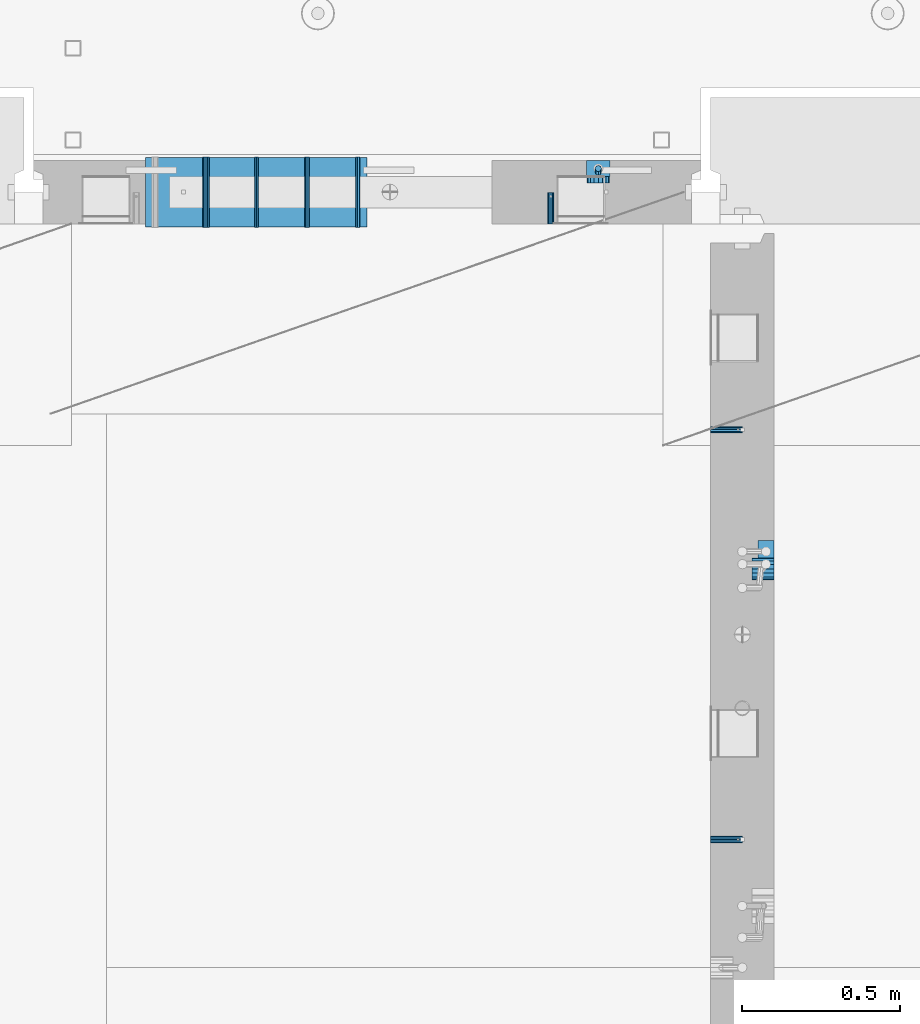
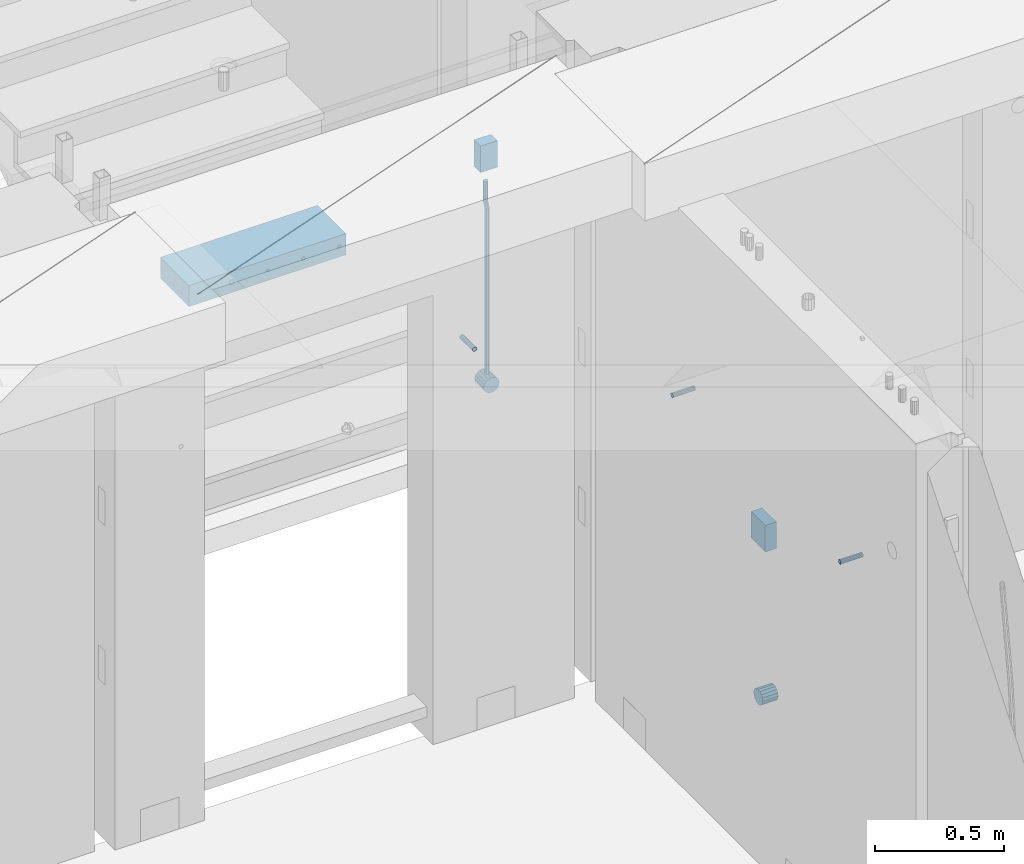
# One storey, part 129 of 325: 13 beams, 5 elements without a shape of their own.
"""IFC2X3 building model written with IfcOpenShell, lengths in millimetres."""

from ifc_helpers import new_model, si_unit, frame, origin_with_axes, place, context, subcontext, project, spatial, faceted_brep, material, type_object, element, aggregate, save


model = new_model("IFC2X3")

# Units and contexts
model_context = context("Model", 3, precision=1e-05, world=origin_with_axes())
body_context = subcontext(model_context, "Body", "Model", "MODEL_VIEW")
ifc_project = project(units=[si_unit("LENGTHUNIT", "METRE", prefix="MILLI"), si_unit("AREAUNIT", "SQUARE_METRE"), si_unit("VOLUMEUNIT", "CUBIC_METRE"), si_unit("MASSUNIT", "GRAM", prefix="KILO"), si_unit("TIMEUNIT", "SECOND"), si_unit("PLANEANGLEUNIT", "RADIAN"), si_unit("SOLIDANGLEUNIT", "STERADIAN"), si_unit("THERMODYNAMICTEMPERATUREUNIT", "DEGREE_CELSIUS"), si_unit("LUMINOUSINTENSITYUNIT", "LUMEN")], contexts=[model_context])

# Site, building, storey
site_placement = place(None, origin_with_axes())
site = spatial("IfcSite", under=ifc_project, at=site_placement, CompositionType="ELEMENT")
building_placement = place(site_placement, origin_with_axes())
building = spatial("IfcBuilding", under=site, at=building_placement, CompositionType="ELEMENT")
storey_placement = place(building_placement, origin_with_axes())
storey = spatial("IfcBuildingStorey", under=building, at=storey_placement, Name="1", CompositionType="ELEMENT", Elevation=0.0)

# Assemblies, beams
assembly_1_placement = place(storey_placement, origin_with_axes())
assembly_1 = element("IfcElementAssembly", 1, at=assembly_1_placement, inside=storey, AssemblyPlace="NOTDEFINED", PredefinedType="REINFORCEMENT_UNIT")
assembly_2_placement = place(assembly_1_placement, origin_with_axes())
assembly_2 = element("IfcElementAssembly", 2, at=assembly_2_placement, Name="Steel Assembly", AssemblyPlace="NOTDEFINED", PredefinedType="RIGID_FRAME")
ifc_material_1 = material(Name="STEEL/Steel_Undefined")
beam_type_1 = type_object("IfcBeamType", PredefinedType="NOTDEFINED")
beam_1_placement = place(assembly_2_placement, frame((21710.0, 14429.9999119589, 83555.0), z_axis=(0.0, 1.0, 0.0), x_axis=(1.0, 0.0, 0.0)))
beam_1 = element("IfcBeam", 3, at=beam_1_placement, type_object=beam_type_1, material=ifc_material_1, Name="M16", context=body_context, shape_type="Brep", body=[
    faceted_brep([(0.0, -8.49999999999272, -1.45519152283669e-11), (0.0, -7.36121593215648, 4.24999999998545), (100.000000000262, -7.36121593215648, 4.24999999998545), (100.000000000262, -8.49999999999272, -1.45519152283669e-11), (0.0, -4.24999999998545, 7.36121593216376), (100.000000000262, -4.24999999998545, 7.36121593216376), (0.0, 1.45519152283669e-11, 8.49999999998545), (100.000000000262, 1.45519152283669e-11, 8.49999999998545), (0.0, 4.25000000001455, 7.36121593216376), (100.000000000262, 4.25000000001455, 7.36121593216376), (0.0, 7.36121593217104, 4.24999999998545), (100.000000000262, 7.36121593217104, 4.24999999998545), (0.0, 8.50000000000728, 0.0), (100.000000000262, 8.50000000000728, 0.0), (0.0, 7.36121593217104, -4.25000000001455), (100.000000000262, 7.36121593217104, -4.25000000001455), (0.0, 4.25000000000728, -7.36121593219286), (100.000000000262, 4.25000000000728, -7.36121593219286), (0.0, 7.27595761418343e-12, -8.5), (100.000000000262, 7.27595761418343e-12, -8.5), (0.0, -4.24999999999272, -7.36121593217831), (100.000000000262, -4.24999999999272, -7.36121593217831), (0.0, -7.36121593215648, -4.25), (100.000000000262, -7.36121593215648, -4.25), (0.0, -10.4999999999927, -1.45519152283669e-11), (0.0, -9.09326673972828, -5.25000000001455), (100.000000000262, -9.09326673972828, -5.25000000001455), (100.000000000262, -10.4999999999927, -1.45519152283669e-11), (0.0, -5.24999999998545, -9.09326673974283), (100.000000000262, -5.24999999998545, -9.09326673974283), (0.0, 7.27595761418343e-12, -10.5), (100.000000000262, 7.27595761418343e-12, -10.5), (0.0, 5.25000000001455, -9.09326673975738), (100.000000000262, 5.25000000001455, -9.09326673975738), (0.0, 9.09326673975011, -5.25000000001455), (100.000000000262, 9.09326673975011, -5.25000000001455), (0.0, 10.5000000000073, -1.45519152283669e-11), (100.000000000262, 10.5000000000073, -1.45519152283669e-11), (0.0, 9.09326673975011, 5.25), (100.000000000262, 9.09326673975011, 5.25), (0.0, 5.25000000000728, 9.09326673972828), (100.000000000262, 5.25000000000728, 9.09326673972828), (0.0, 1.45519152283669e-11, 10.4999999999854), (100.000000000262, 1.45519152283669e-11, 10.4999999999854), (0.0, -5.24999999999272, 9.09326673972828), (100.000000000262, -5.24999999999272, 9.09326673972828), (0.0, -9.09326673972828, 5.24999999998545), (100.000000000262, -9.09326673972828, 5.24999999998545)], [[[0, 1, 2, 3]], [[1, 4, 5, 2]], [[4, 6, 7, 5]], [[6, 8, 9, 7]], [[8, 10, 11, 9]], [[10, 12, 13, 11]], [[12, 14, 15, 13]], [[14, 16, 17, 15]], [[16, 18, 19, 17]], [[18, 20, 21, 19]], [[20, 22, 23, 21]], [[22, 0, 3, 23]], [[24, 25, 26, 27]], [[25, 28, 29, 26]], [[28, 30, 31, 29]], [[30, 32, 33, 31]], [[32, 34, 35, 33]], [[34, 36, 37, 35]], [[36, 38, 39, 37]], [[38, 40, 41, 39]], [[40, 42, 43, 41]], [[42, 44, 45, 43]], [[44, 46, 47, 45]], [[46, 24, 27, 47]], [[29, 31, 33, 35, 37, 39, 41, 43, 45, 47, 27, 26], [5, 7, 9, 11, 13, 15, 17, 19, 21, 23, 3, 2]], [[46, 44, 42, 40, 38, 36, 34, 32, 30, 28, 25, 24], [22, 20, 18, 16, 14, 12, 10, 8, 6, 4, 1, 0]]]),
])
aggregate(assembly_2, [beam_1])
assembly_3_placement = place(assembly_1_placement, origin_with_axes())
assembly_3 = element("IfcElementAssembly", 4, at=assembly_3_placement, Name="Steel Assembly", AssemblyPlace="NOTDEFINED", PredefinedType="RIGID_FRAME")
beam_2_placement = place(assembly_3_placement, frame((21710.0, 13134.9999119588, 83555.0), z_axis=(0.0, -1.0, 0.0), x_axis=(1.0, 0.0, 0.0)))
beam_2 = element("IfcBeam", 5, at=beam_2_placement, type_object=beam_type_1, material=ifc_material_1, Name="M16", context=body_context, shape_type="Brep", body=[
    faceted_brep([(0.0, -8.49999999999272, -1.45519152283669e-11), (0.0, -7.36121593215648, 4.24999999998545), (100.000000000262, -7.36121593215648, 4.24999999998545), (100.000000000262, -8.49999999999272, -1.45519152283669e-11), (0.0, -4.24999999998545, 7.36121593216376), (100.000000000262, -4.24999999998545, 7.36121593216376), (0.0, 1.45519152283669e-11, 8.49999999998545), (100.000000000262, 1.45519152283669e-11, 8.49999999998545), (0.0, 4.25000000001455, 7.36121593216376), (100.000000000262, 4.25000000001455, 7.36121593216376), (0.0, 7.36121593217104, 4.24999999998545), (100.000000000262, 7.36121593217104, 4.24999999998545), (0.0, 8.50000000000728, 0.0), (100.000000000262, 8.50000000000728, 0.0), (0.0, 7.36121593217104, -4.25000000001455), (100.000000000262, 7.36121593217104, -4.25000000001455), (0.0, 4.25000000000728, -7.36121593219286), (100.000000000262, 4.25000000000728, -7.36121593219286), (0.0, 7.27595761418343e-12, -8.5), (100.000000000262, 7.27595761418343e-12, -8.5), (0.0, -4.24999999999272, -7.36121593217831), (100.000000000262, -4.24999999999272, -7.36121593217831), (0.0, -7.36121593215648, -4.25), (100.000000000262, -7.36121593215648, -4.25), (0.0, -10.4999999999927, -1.45519152283669e-11), (0.0, -9.09326673972828, -5.25000000001455), (100.000000000262, -9.09326673972828, -5.25000000001455), (100.000000000262, -10.4999999999927, -1.45519152283669e-11), (0.0, -5.24999999998545, -9.09326673974283), (100.000000000262, -5.24999999998545, -9.09326673974283), (0.0, 7.27595761418343e-12, -10.5), (100.000000000262, 7.27595761418343e-12, -10.5), (0.0, 5.25000000001455, -9.09326673975738), (100.000000000262, 5.25000000001455, -9.09326673975738), (0.0, 9.09326673975011, -5.25000000001455), (100.000000000262, 9.09326673975011, -5.25000000001455), (0.0, 10.5000000000073, -1.45519152283669e-11), (100.000000000262, 10.5000000000073, -1.45519152283669e-11), (0.0, 9.09326673975011, 5.25), (100.000000000262, 9.09326673975011, 5.25), (0.0, 5.25000000000728, 9.09326673972828), (100.000000000262, 5.25000000000728, 9.09326673972828), (0.0, 1.45519152283669e-11, 10.4999999999854), (100.000000000262, 1.45519152283669e-11, 10.4999999999854), (0.0, -5.24999999999272, 9.09326673972828), (100.000000000262, -5.24999999999272, 9.09326673972828), (0.0, -9.09326673972828, 5.24999999998545), (100.000000000262, -9.09326673972828, 5.24999999998545)], [[[0, 1, 2, 3]], [[1, 4, 5, 2]], [[4, 6, 7, 5]], [[6, 8, 9, 7]], [[8, 10, 11, 9]], [[10, 12, 13, 11]], [[12, 14, 15, 13]], [[14, 16, 17, 15]], [[16, 18, 19, 17]], [[18, 20, 21, 19]], [[20, 22, 23, 21]], [[22, 0, 3, 23]], [[24, 25, 26, 27]], [[25, 28, 29, 26]], [[28, 30, 31, 29]], [[30, 32, 33, 31]], [[32, 34, 35, 33]], [[34, 36, 37, 35]], [[36, 38, 39, 37]], [[38, 40, 41, 39]], [[40, 42, 43, 41]], [[42, 44, 45, 43]], [[44, 46, 47, 45]], [[46, 24, 27, 47]], [[29, 31, 33, 35, 37, 39, 41, 43, 45, 47, 27, 26], [5, 7, 9, 11, 13, 15, 17, 19, 21, 23, 3, 2]], [[46, 44, 42, 40, 38, 36, 34, 32, 30, 28, 25, 24], [22, 20, 18, 16, 14, 12, 10, 8, 6, 4, 1, 0]]]),
])
aggregate(assembly_3, [beam_2])

assembly_4_placement = place(storey_placement, origin_with_axes())
assembly_4 = element("IfcElementAssembly", 6, at=assembly_4_placement, inside=storey, AssemblyPlace="NOTDEFINED", PredefinedType="REINFORCEMENT_UNIT")
assembly_5_placement = place(assembly_4_placement, origin_with_axes())
assembly_5 = element("IfcElementAssembly", 7, at=assembly_5_placement, Name="Steel Assembly", AssemblyPlace="NOTDEFINED", PredefinedType="RIGID_FRAME")
beam_3_placement = place(assembly_5_placement, frame((21205.004085231, 15080.0, 83555.0), z_axis=(1.0, 0.0, 0.0), x_axis=(0.0, 1.0, 0.0)))
beam_3 = element("IfcBeam", 8, at=beam_3_placement, type_object=beam_type_1, material=ifc_material_1, Name="M16", context=body_context, shape_type="Brep", body=[
    faceted_brep([(0.0, -8.49999999999272, -1.45519152283669e-11), (0.0, -7.36121593215648, 4.24999999998545), (100.000000000262, -7.36121593215648, 4.24999999998545), (100.000000000262, -8.49999999999272, -1.45519152283669e-11), (0.0, -4.24999999998545, 7.36121593216376), (100.000000000262, -4.24999999998545, 7.36121593216376), (0.0, 1.45519152283669e-11, 8.49999999998545), (100.000000000262, 1.45519152283669e-11, 8.49999999998545), (0.0, 4.25000000001455, 7.36121593216376), (100.000000000262, 4.25000000001455, 7.36121593216376), (0.0, 7.36121593217104, 4.24999999998545), (100.000000000262, 7.36121593217104, 4.24999999998545), (0.0, 8.50000000000728, 0.0), (100.000000000262, 8.50000000000728, 0.0), (0.0, 7.36121593217104, -4.25000000001455), (100.000000000262, 7.36121593217104, -4.25000000001455), (0.0, 4.25000000000728, -7.36121593219286), (100.000000000262, 4.25000000000728, -7.36121593219286), (0.0, 7.27595761418343e-12, -8.5), (100.000000000262, 7.27595761418343e-12, -8.5), (0.0, -4.24999999999272, -7.36121593217831), (100.000000000262, -4.24999999999272, -7.36121593217831), (0.0, -7.36121593215648, -4.25), (100.000000000262, -7.36121593215648, -4.25), (0.0, -10.4999999999927, -1.45519152283669e-11), (0.0, -9.09326673972828, -5.25000000001455), (100.000000000262, -9.09326673972828, -5.25000000001455), (100.000000000262, -10.4999999999927, -1.45519152283669e-11), (0.0, -5.24999999998545, -9.09326673974283), (100.000000000262, -5.24999999998545, -9.09326673974283), (0.0, 7.27595761418343e-12, -10.5), (100.000000000262, 7.27595761418343e-12, -10.5), (0.0, 5.25000000001455, -9.09326673975738), (100.000000000262, 5.25000000001455, -9.09326673975738), (0.0, 9.09326673975011, -5.25000000001455), (100.000000000262, 9.09326673975011, -5.25000000001455), (0.0, 10.5000000000073, -1.45519152283669e-11), (100.000000000262, 10.5000000000073, -1.45519152283669e-11), (0.0, 9.09326673975011, 5.25), (100.000000000262, 9.09326673975011, 5.25), (0.0, 5.25000000000728, 9.09326673972828), (100.000000000262, 5.25000000000728, 9.09326673972828), (0.0, 1.45519152283669e-11, 10.4999999999854), (100.000000000262, 1.45519152283669e-11, 10.4999999999854), (0.0, -5.24999999999272, 9.09326673972828), (100.000000000262, -5.24999999999272, 9.09326673972828), (0.0, -9.09326673972828, 5.24999999998545), (100.000000000262, -9.09326673972828, 5.24999999998545)], [[[0, 1, 2, 3]], [[1, 4, 5, 2]], [[4, 6, 7, 5]], [[6, 8, 9, 7]], [[8, 10, 11, 9]], [[10, 12, 13, 11]], [[12, 14, 15, 13]], [[14, 16, 17, 15]], [[16, 18, 19, 17]], [[18, 20, 21, 19]], [[20, 22, 23, 21]], [[22, 0, 3, 23]], [[24, 25, 26, 27]], [[25, 28, 29, 26]], [[28, 30, 31, 29]], [[30, 32, 33, 31]], [[32, 34, 35, 33]], [[34, 36, 37, 35]], [[36, 38, 39, 37]], [[38, 40, 41, 39]], [[40, 42, 43, 41]], [[42, 44, 45, 43]], [[44, 46, 47, 45]], [[46, 24, 27, 47]], [[29, 31, 33, 35, 37, 39, 41, 43, 45, 47, 27, 26], [5, 7, 9, 11, 13, 15, 17, 19, 21, 23, 3, 2]], [[46, 44, 42, 40, 38, 36, 34, 32, 30, 28, 25, 24], [22, 20, 18, 16, 14, 12, 10, 8, 6, 4, 1, 0]]]),
])
aggregate(assembly_5, [beam_3])
ifc_material_2 = material()
beam_type_2 = type_object("IfcBeamType", Name="D20", PredefinedType="NOTDEFINED")
beam_4_placement = place(assembly_4_placement, frame((21354.9999999958, 15245.0000022759, 83290.0), z_axis=(0.00020576299992186, -0.999642804629538, -0.0267249099901004), x_axis=(-4.30000201928125e-08, -0.0267249099948059, 0.999642825806181)))
beam_4 = element("IfcBeam", 9, at=beam_4_placement, type_object=beam_type_2, material=ifc_material_2, Name="JM20", ObjectType="D20", context=body_context, shape_type="Brep", body=[
    faceted_brep([(0.0, -10.0, 0.0), (-4.19531716033816e-08, -7.07106781186667, -7.07106781187031), (60.3581158964225, -7.07106779467358, -7.07106780560207), (60.3581159005553, -9.99999998281055, 6.26459950581193e-09), (0.0, 0.0, -10.0), (60.3581158930319, 1.71930878423154e-08, -9.9999999937354), (4.196772351861e-08, 7.07106781186303, -7.07106781186667), (60.3581158923917, 7.07106782905612, -7.07106780560207), (0.0, 10.0, 0.0), (60.3581158948509, 10.0000000171895, 6.26459950581193e-09), (4.196772351861e-08, 7.07106781185939, 7.07106781185939), (60.3581158989837, 7.07106782905612, 7.07106781813127), (0.0, 0.0, 10.0), (60.3581159023597, 1.71930878423154e-08, 10.0000000062646), (-4.19531716033816e-08, -7.07106781187031, 7.07106781185939), (60.358115903, -7.07106779467722, 7.07106781813127), (60.8972477222414, -7.07106779452079, -7.07106780554386), (60.991799419251, -9.99999998403655, 6.21366780251265e-09), (60.8581158930319, 1.7334969015792e-08, -9.99999999368447), (60.8972861483926, 7.07106782920528, -7.07106780554386), (60.9917724058905, 10.0000000159635, 6.21366780251265e-09), (61.0863241029147, 7.07106782926348, 7.07106781820403), (61.1254559321096, 1.7415004549548e-08, 10.0000000063446), (61.086285676749, -7.07106779446985, 7.07106781820403), (61.4361869218264, -7.07107072394501, -7.08547838249069), (61.6251751877571, -10.0000034255863, -0.0169367769813107), (61.35793724822, -2.69946758635342e-06, -10.0133646071736), (61.4362637644808, 7.07106489957732, -7.08547940969947), (61.6252838596702, 9.99999657411536, -0.0169382296771801), (61.8142721256008, 7.07106387247404, 7.0516033758322), (61.8925217992073, -4.15200702263974e-06, 9.97948960051872), (61.814195282961, -7.07107175104829, 7.05160440304098), (775.690073058257, -7.07495307777208, -26.1837562433175), (775.879061324187, -10.0038857794134, -19.1152146378081), (775.611823384636, -0.00388505329101463, -29.1116424680004), (775.690149900896, 7.06718254575026, -26.1837572705263), (775.8791699961, 9.99611422029193, -19.1152160905003), (776.068158262031, 7.06718151865061, -12.0466744849909), (776.146407935637, -0.00388650583045091, -9.11878826030807), (776.068081419377, -7.07495410487172, -12.0466734577822), (776.844979390982, -7.07495935530824, -26.2146370302071), (778.703176670489, -10.0039011299996, -19.1907280380728), (776.111644739809, -0.00388777008629404, -29.1250070814895), (776.932750209904, 7.0671757915552, -26.2169828873994), (778.827303353013, 9.99609819560283, -19.1940455811236), (780.685500632535, 7.06715642091513, -12.1701365889894), (781.418835283708, -0.00391516431045602, -9.25976653770704), (780.597729813613, -7.07497872594467, -12.1677907318008), (777.861329320964, -7.08852484077215, -26.7638283058368), (781.188477298943, -10.0370730804789, -20.5336763496562), (776.551501535956, -0.00975865254440578, -29.362686553719), (778.026273295982, 7.05258025600779, -26.8078751783723), (781.421743305415, 9.96146953432981, -20.595968034173), (784.74889128338, 7.01292129462308, -14.3658160779887), (786.058719068402, -0.0658448936046625, -11.7669578301065), (784.583947308391, -7.12818380215685, -14.3217692054532), (795.432392943592, -7.32305037289916, -36.2584664814858), (798.759540921557, -10.2715986126059, -30.0283145252979), (794.12256515857, -0.244284184671415, -38.8573247293643), (795.597336918581, 6.81805472388078, -36.3025133540177), (798.992806928029, 9.72694400219916, -30.0906062098184), (802.319954905994, 6.77839576249244, -23.8604542536341), (803.629782691016, -0.300370425735309, -21.2615960057519), (802.15501093099, -7.3627093342875, -23.8164073811022), (799.505846831846, -7.3774198158244, -38.4595837060842), (801.367995818946, -10.3064143349802, -31.4378100447575), (798.762755292832, -0.306218002893729, -41.3646815597422), (799.574014147365, 6.7649769840682, -38.4513366830724), (801.464398961049, 9.69395502388943, -31.4261469929661), (803.32654794812, 6.76496050473361, -24.4043733316357), (804.069639487148, -0.306241308189783, -21.4992754779851), (803.258380632629, -7.37743629515535, -24.4126203546512), (804.134608044958, -7.36363999659807, -38.5831936197719), (804.332044311042, -10.2975903644801, -31.5169642204455), (804.035512197443, -0.290521008897485, -41.5054892177468), (804.092805771987, 6.77842942390271, -38.5720098863276), (804.272926969657, 9.70231601001069, -31.5011480329304), (804.470363235741, 6.76836564212863, -24.434918633604), (804.569459083272, -0.304753345568315, -21.5126230356327), (804.512165508728, -7.37370377836123, -24.4461023670447), (901.742523775247, -7.07306129268909, -41.1897886639781), (901.939960041316, -10.0070116605639, -34.1235592646481), (901.643427927731, 5.76950078539085e-05, -44.1120842619457), (901.700721502275, 7.06900812780805, -41.1786049305338), (901.880842699946, 9.99289471391967, -34.1077430771329), (902.07827896603, 7.05894434603761, -27.0415136778065), (902.177374813546, -0.0141746416556998, -24.1192180798353), (902.120081238987, -7.08312507445589, -27.0526974112508)], [[[0, 1, 2, 3]], [[1, 4, 5, 2]], [[4, 6, 7, 5]], [[6, 8, 9, 7]], [[8, 10, 11, 9]], [[10, 12, 13, 11]], [[12, 14, 15, 13]], [[14, 0, 3, 15]], [[14, 12, 10, 8, 6, 4, 1, 0]], [[3, 2, 16, 17]], [[2, 5, 18, 16]], [[5, 7, 19, 18]], [[7, 9, 20, 19]], [[9, 11, 21, 20]], [[11, 13, 22, 21]], [[13, 15, 23, 22]], [[15, 3, 17, 23]], [[17, 16, 24, 25]], [[16, 18, 26, 24]], [[18, 19, 27, 26]], [[19, 20, 28, 27]], [[20, 21, 29, 28]], [[21, 22, 30, 29]], [[22, 23, 31, 30]], [[23, 17, 25, 31]], [[25, 24, 32, 33]], [[24, 26, 34, 32]], [[26, 27, 35, 34]], [[27, 28, 36, 35]], [[28, 29, 37, 36]], [[29, 30, 38, 37]], [[30, 31, 39, 38]], [[31, 25, 33, 39]], [[33, 32, 40, 41]], [[32, 34, 42, 40]], [[34, 35, 43, 42]], [[35, 36, 44, 43]], [[36, 37, 45, 44]], [[37, 38, 46, 45]], [[38, 39, 47, 46]], [[39, 33, 41, 47]], [[41, 40, 48, 49]], [[40, 42, 50, 48]], [[42, 43, 51, 50]], [[43, 44, 52, 51]], [[44, 45, 53, 52]], [[45, 46, 54, 53]], [[46, 47, 55, 54]], [[47, 41, 49, 55]], [[49, 48, 56, 57]], [[48, 50, 58, 56]], [[50, 51, 59, 58]], [[51, 52, 60, 59]], [[52, 53, 61, 60]], [[53, 54, 62, 61]], [[54, 55, 63, 62]], [[55, 49, 57, 63]], [[57, 56, 64, 65]], [[56, 58, 66, 64]], [[58, 59, 67, 66]], [[59, 60, 68, 67]], [[60, 61, 69, 68]], [[61, 62, 70, 69]], [[62, 63, 71, 70]], [[63, 57, 65, 71]], [[65, 64, 72, 73]], [[64, 66, 74, 72]], [[66, 67, 75, 74]], [[67, 68, 76, 75]], [[68, 69, 77, 76]], [[69, 70, 78, 77]], [[70, 71, 79, 78]], [[71, 65, 73, 79]], [[73, 72, 80, 81]], [[72, 74, 82, 80]], [[74, 75, 83, 82]], [[75, 76, 84, 83]], [[76, 77, 85, 84]], [[77, 78, 86, 85]], [[78, 79, 87, 86]], [[79, 73, 81, 87]], [[82, 83, 84, 85, 86, 87, 81, 80]]]),
])

# Beam
beam_type_3 = type_object("IfcBeamType", Name="D70", PredefinedType="NOTDEFINED")
beam_5_placement = place(assembly_1_placement, frame((21910.0000022791, 13990.0, 82355.0), z_axis=(0.0, 0.0, 1.0), x_axis=(-1.0, 3.00000001838171e-08, 0.0)))
beam_5 = element("IfcBeam", 10, at=beam_5_placement, type_object=beam_type_3, material=ifc_material_2, ObjectType="D70", context=body_context, shape_type="Brep", body=[
    faceted_brep([(0.0, -35.0, 0.0), (0.0, -32.3357836378964, -13.3939201327739), (70.0, -32.3357836378964, -13.3939201327739), (70.0, -35.0, 0.0), (0.0, -24.7487373415279, -24.7487373415352), (70.0, -24.7487373415279, -24.7487373415352), (0.0, -13.3939201327776, -32.3357836379), (70.0, -13.3939201327776, -32.3357836379), (0.0, 0.0, -35.0), (70.0, 0.0, -35.0), (0.0, 13.3939201327776, -32.3357836379), (70.0, 13.3939201327776, -32.3357836379), (0.0, 24.7487373415279, -24.7487373415352), (70.0, 24.7487373415279, -24.7487373415352), (0.0, 32.3357836378964, -13.3939201327739), (70.0, 32.3357836378964, -13.3939201327739), (0.0, 35.0, 0.0), (70.0, 35.0, 0.0), (0.0, 32.3357836378964, 13.3939201327739), (70.0, 32.3357836378964, 13.3939201327739), (0.0, 24.7487373415279, 24.7487373415352), (70.0, 24.7487373415279, 24.7487373415352), (0.0, 13.3939201327776, 32.3357836379), (70.0, 13.3939201327776, 32.3357836379), (0.0, 0.0, 35.0), (70.0, 0.0, 35.0), (0.0, -13.3939201327776, 32.3357836379), (70.0, -13.3939201327776, 32.3357836379), (0.0, -24.7487373415279, 24.7487373415352), (70.0, -24.7487373415279, 24.7487373415352), (0.0, -32.3357836378964, 13.3939201327739), (70.0, -32.3357836378964, 13.3939201327739)], [[[0, 1, 2, 3]], [[1, 4, 5, 2]], [[4, 6, 7, 5]], [[6, 8, 9, 7]], [[8, 10, 11, 9]], [[10, 12, 13, 11]], [[12, 14, 15, 13]], [[14, 16, 17, 15]], [[16, 18, 19, 17]], [[18, 20, 21, 19]], [[20, 22, 23, 21]], [[22, 24, 25, 23]], [[24, 26, 27, 25]], [[26, 28, 29, 27]], [[28, 30, 31, 29]], [[30, 0, 3, 31]], [[5, 7, 9, 11, 13, 15, 17, 19, 21, 23, 25, 27, 29, 31, 3, 2]], [[30, 28, 26, 24, 22, 20, 18, 16, 14, 12, 10, 8, 6, 4, 1, 0]]]),
])

beam_6_placement = place(assembly_4_placement, frame((21354.9999999996, 15280.0000022759, 83255.0), z_axis=(0.0, 0.0, 1.0), x_axis=(0.0, -1.0, 0.0)))
beam_6 = element("IfcBeam", 11, at=beam_6_placement, type_object=beam_type_3, material=ifc_material_2, ObjectType="D70", context=body_context, shape_type="Brep", body=[
    faceted_brep([(0.0, -35.0, 0.0), (0.0, -32.3357836378964, -13.3939201327739), (70.0, -32.3357836378964, -13.3939201327739), (70.0, -35.0, 0.0), (0.0, -24.7487373415279, -24.7487373415352), (70.0, -24.7487373415279, -24.7487373415352), (0.0, -13.3939201327776, -32.3357836379), (70.0, -13.3939201327776, -32.3357836379), (0.0, 0.0, -35.0), (70.0, 0.0, -35.0), (0.0, 13.3939201327776, -32.3357836379), (70.0, 13.3939201327776, -32.3357836379), (0.0, 24.7487373415279, -24.7487373415352), (70.0, 24.7487373415279, -24.7487373415352), (0.0, 32.3357836378964, -13.3939201327739), (70.0, 32.3357836378964, -13.3939201327739), (0.0, 35.0, 0.0), (70.0, 35.0, 0.0), (0.0, 32.3357836378964, 13.3939201327739), (70.0, 32.3357836378964, 13.3939201327739), (0.0, 24.7487373415279, 24.7487373415352), (70.0, 24.7487373415279, 24.7487373415352), (0.0, 13.3939201327776, 32.3357836379), (70.0, 13.3939201327776, 32.3357836379), (0.0, 0.0, 35.0), (70.0, 0.0, 35.0), (0.0, -13.3939201327776, 32.3357836379), (70.0, -13.3939201327776, 32.3357836379), (0.0, -24.7487373415279, 24.7487373415352), (70.0, -24.7487373415279, 24.7487373415352), (0.0, -32.3357836378964, 13.3939201327739), (70.0, -32.3357836378964, 13.3939201327739)], [[[0, 1, 2, 3]], [[1, 4, 5, 2]], [[4, 6, 7, 5]], [[6, 8, 9, 7]], [[8, 10, 11, 9]], [[10, 12, 13, 11]], [[12, 14, 15, 13]], [[14, 16, 17, 15]], [[16, 18, 19, 17]], [[18, 20, 21, 19]], [[20, 22, 23, 21]], [[22, 24, 25, 23]], [[24, 26, 27, 25]], [[26, 28, 29, 27]], [[28, 30, 31, 29]], [[30, 0, 3, 31]], [[5, 7, 9, 11, 13, 15, 17, 19, 21, 23, 25, 27, 29, 31, 3, 2]], [[30, 28, 26, 24, 22, 20, 18, 16, 14, 12, 10, 8, 6, 4, 1, 0]]]),
])

ifc_material_3 = material()
beam_type_4 = type_object("IfcBeamType", Name="D12", PredefinedType="NOTDEFINED")
beam_7_placement = place(assembly_4_placement, frame((20274.9991455079, 15068.9997314798, 84260.0), z_axis=(-1.0, 3.00000001838171e-08, 0.0), x_axis=(0.0, 1.0, 0.0)))
beam_7 = element("IfcBeam", 12, at=beam_7_placement, type_object=beam_type_4, material=ifc_material_3, Name="12", ObjectType="D12", context=body_context, shape_type="Brep", body=[
    faceted_brep([(0.0, -6.0, -1.45519152283669e-11), (0.0, -4.24264068712, -4.24264068713819), (222.000077784061, -4.24264068712364, -4.24264068712), (222.000077784061, -6.0, 0.0), (3.63797880709171e-12, 0.0, -6.0000000000291), (222.000077784061, 0.0, -6.0), (0.0, 4.24264068712, -4.24264068713819), (222.000077784061, 4.24264068712364, -4.24264068712), (0.0, 6.0, -1.45519152283669e-11), (222.000077784061, 6.0, 0.0), (0.0, 4.24264068712, 4.24264068709454), (222.000077784061, 4.24264068712364, 4.24264068712), (0.0, 0.0, 5.99999999998545), (222.000077784061, 0.0, 6.0), (0.0, -4.24264068712, 4.24264068709454), (222.000077784061, -4.24264068712364, 4.24264068712)], [[[0, 1, 2, 3]], [[1, 4, 5, 2]], [[4, 6, 7, 5]], [[6, 8, 9, 7]], [[8, 10, 11, 9]], [[10, 12, 13, 11]], [[12, 14, 15, 13]], [[14, 0, 3, 15]], [[5, 7, 9, 11, 13, 15, 3, 2]], [[14, 12, 10, 8, 6, 4, 1, 0]]]),
])

beam_type_5 = type_object("IfcBeamType", Name="D15", PredefinedType="NOTDEFINED")
beam_8_placement = place(assembly_4_placement, frame((20594.99899292, 15068.9997314793, 84260.0), z_axis=(-1.0, 3.00000001838171e-08, 0.0), x_axis=(0.0, 1.0, 0.0)))
beam_8 = element("IfcBeam", 13, at=beam_8_placement, type_object=beam_type_5, material=ifc_material_3, Name="15", ObjectType="D15", context=body_context, shape_type="Brep", body=[
    faceted_brep([(0.0, -7.5, 0.0), (0.0, -5.30330085889727, -5.30330085890091), (222.000077784061, -5.30330085889727, -5.30330085890091), (222.000077784061, -7.5, 0.0), (0.0, 1.45519152283669e-11, -7.5), (222.000077784061, 0.0, -7.5), (0.0, 5.30330085889727, -5.30330085890091), (222.000077784061, 5.30330085889727, -5.30330085890091), (0.0, 7.5, 0.0), (222.000077784061, 7.5, 0.0), (0.0, 5.30330085889727, 5.30330085890091), (222.000077784061, 5.30330085889727, 5.30330085890091), (0.0, 1.45519152283669e-11, 7.5), (222.000077784061, 0.0, 7.5), (0.0, -5.30330085889727, 5.30330085890091), (222.000077784061, -5.30330085889727, 5.30330085890091)], [[[0, 1, 2, 3]], [[1, 4, 5, 2]], [[4, 6, 7, 5]], [[6, 8, 9, 7]], [[8, 10, 11, 9]], [[10, 12, 13, 11]], [[12, 14, 15, 13]], [[14, 0, 3, 15]], [[5, 7, 9, 11, 13, 15, 3, 2]], [[14, 12, 10, 8, 6, 4, 1, 0]]]),
])

beam_9_placement = place(assembly_4_placement, frame((20434.9991455079, 15068.9997314796, 84260.0), z_axis=(-1.0, 3.00000001838171e-08, 0.0), x_axis=(0.0, 1.0, 0.0)))
beam_9 = element("IfcBeam", 14, at=beam_9_placement, type_object=beam_type_5, material=ifc_material_3, Name="15", ObjectType="D15", context=body_context, shape_type="Brep", body=[
    faceted_brep([(0.0, -7.5, 0.0), (0.0, -5.30330085889727, -5.30330085890091), (222.000077784061, -5.30330085889727, -5.30330085890091), (222.000077784061, -7.5, 0.0), (0.0, 1.45519152283669e-11, -7.5), (222.000077784061, 0.0, -7.5), (0.0, 5.30330085889727, -5.30330085890091), (222.000077784061, 5.30330085889727, -5.30330085890091), (0.0, 7.5, 0.0), (222.000077784061, 7.5, 0.0), (0.0, 5.30330085889727, 5.30330085890091), (222.000077784061, 5.30330085889727, 5.30330085890091), (0.0, 1.45519152283669e-11, 7.5), (222.000077784061, 0.0, 7.5), (0.0, -5.30330085889727, 5.30330085890091), (222.000077784061, -5.30330085889727, 5.30330085890091)], [[[0, 1, 2, 3]], [[1, 4, 5, 2]], [[4, 6, 7, 5]], [[6, 8, 9, 7]], [[8, 10, 11, 9]], [[10, 12, 13, 11]], [[12, 14, 15, 13]], [[14, 0, 3, 15]], [[5, 7, 9, 11, 13, 15, 3, 2]], [[14, 12, 10, 8, 6, 4, 1, 0]]]),
])

beam_type_6 = type_object("IfcBeamType", Name="D22", PredefinedType="NOTDEFINED")
beam_10_placement = place(assembly_4_placement, frame((20114.9991455079, 15068.9997314801, 84260.0), z_axis=(-1.0, 3.00000001838171e-08, 0.0), x_axis=(0.0, 1.0, 0.0)))
beam_10 = element("IfcBeam", 15, at=beam_10_placement, type_object=beam_type_6, material=ifc_material_3, Name="22", ObjectType="D22", context=body_context, shape_type="Brep", body=[
    faceted_brep([(0.0, -11.0, 0.0), (0.0, -9.52627944163396, -5.5), (222.000077784061, -9.52627944163396, -5.5), (222.000077784061, -11.0, 0.0), (0.0, -5.5, -9.52627944163032), (222.000077784061, -5.5, -9.52627944163032), (0.0, 0.0, -11.0), (222.000077784061, 0.0, -11.0), (0.0, 5.5, -9.52627944163032), (222.000077784061, 5.5, -9.52627944163032), (0.0, 9.52627944163396, -5.5), (222.000077784061, 9.52627944163396, -5.5), (0.0, 11.0, 0.0), (222.000077784061, 11.0, 0.0), (0.0, 9.52627944163396, 5.5), (222.000077784061, 9.52627944163396, 5.5), (0.0, 5.5, 9.52627944163032), (222.000077784061, 5.5, 9.52627944163032), (0.0, 0.0, 11.0), (222.000077784061, 0.0, 11.0), (0.0, -5.5, 9.52627944163032), (222.000077784061, -5.5, 9.52627944163032), (0.0, -9.52627944163396, 5.5), (222.000077784061, -9.52627944163396, 5.5)], [[[0, 1, 2, 3]], [[1, 4, 5, 2]], [[4, 6, 7, 5]], [[6, 8, 9, 7]], [[8, 10, 11, 9]], [[10, 12, 13, 11]], [[12, 14, 15, 13]], [[14, 16, 17, 15]], [[16, 18, 19, 17]], [[18, 20, 21, 19]], [[20, 22, 23, 21]], [[22, 0, 3, 23]], [[5, 7, 9, 11, 13, 15, 17, 19, 21, 23, 3, 2]], [[22, 20, 18, 16, 14, 12, 10, 8, 6, 4, 1, 0]]]),
])

beam_type_7 = type_object("IfcBeamType", PredefinedType="NOTDEFINED")
beam_11_placement = place(assembly_4_placement, frame((20274.9991455078, 15069.9997314811, 84260.0), z_axis=(-1.0, 3.00000001838171e-08, 0.0), x_axis=(0.0, 1.0, 0.0)))
beam_11 = element("IfcBeam", 16, at=beam_11_placement, type_object=beam_type_7, material=ifc_material_3, context=body_context, shape_type="Brep", body=[
    faceted_brep([(0.0, 50.0, -350.0), (0.0, 50.0, 350.0), (220.000077784061, 50.0, 350.0), (220.000077784061, 50.0, -350.0), (0.0, -50.0, 350.0), (220.000077784061, -50.0, 350.0), (0.0, -50.0, -350.0), (220.000077784061, -50.0, -350.0)], [[[0, 1, 2, 3]], [[1, 4, 5, 2]], [[4, 6, 7, 5]], [[6, 0, 3, 7]], [[5, 7, 3, 2]], [[6, 4, 1, 0]]]),
])

beam_type_8 = type_object("IfcBeamType", Name="125X50", PredefinedType="NOTDEFINED")
beam_12_placement = place(assembly_1_placement, frame((21885.0, 13970.0, 83105.0), z_axis=(0.0, 0.0, 1.0), x_axis=(0.0, 1.0, 0.0)))
beam_12 = element("IfcBeam", 17, at=beam_12_placement, type_object=beam_type_8, material=ifc_material_2, Name="WM2", ObjectType="125X50", context=body_context, shape_type="Brep", body=[
    faceted_brep([(0.0, 25.0, -62.5), (0.0, 25.0, 62.5), (110.0, 25.0, 62.5), (110.0, 25.0, -62.5), (0.0, -25.0, 62.5), (110.0, -25.0, 62.5), (0.0, -25.0, -62.5), (110.0, -25.0, -62.5)], [[[0, 1, 2, 3]], [[1, 4, 5, 2]], [[4, 6, 7, 5]], [[6, 0, 3, 7]], [[5, 7, 3, 2]], [[0, 6, 4, 1]]]),
])

aggregate(assembly_1, [assembly_2, assembly_3, beam_12, beam_5])

beam_13_placement = place(assembly_4_placement, frame((21392.4999999996, 15254.9999999967, 84320.0), z_axis=(0.0, 0.0, 1.0), x_axis=(-1.0, 3.00000001838171e-08, 0.0)))
beam_13 = element("IfcBeam", 18, at=beam_13_placement, type_object=beam_type_8, material=ifc_material_2, Name="WM1", ObjectType="125X50", context=body_context, shape_type="Brep", body=[
    faceted_brep([(0.0, 25.0, -62.5), (0.0, 25.0, 62.5), (75.0, 25.0, 62.5), (75.0, 25.0, -62.5), (0.0, -25.0, 62.5), (75.0, -25.0, 62.5), (0.0, -25.0, -62.5), (75.0, -25.0, -62.5)], [[[0, 1, 2, 3]], [[1, 4, 5, 2]], [[4, 6, 7, 5]], [[6, 0, 3, 7]], [[5, 7, 3, 2]], [[0, 6, 4, 1]]]),
])

aggregate(assembly_4, [assembly_5, beam_13, beam_4, beam_6, beam_10, beam_7, beam_11, beam_8, beam_9])

save(model, "model.ifc")
